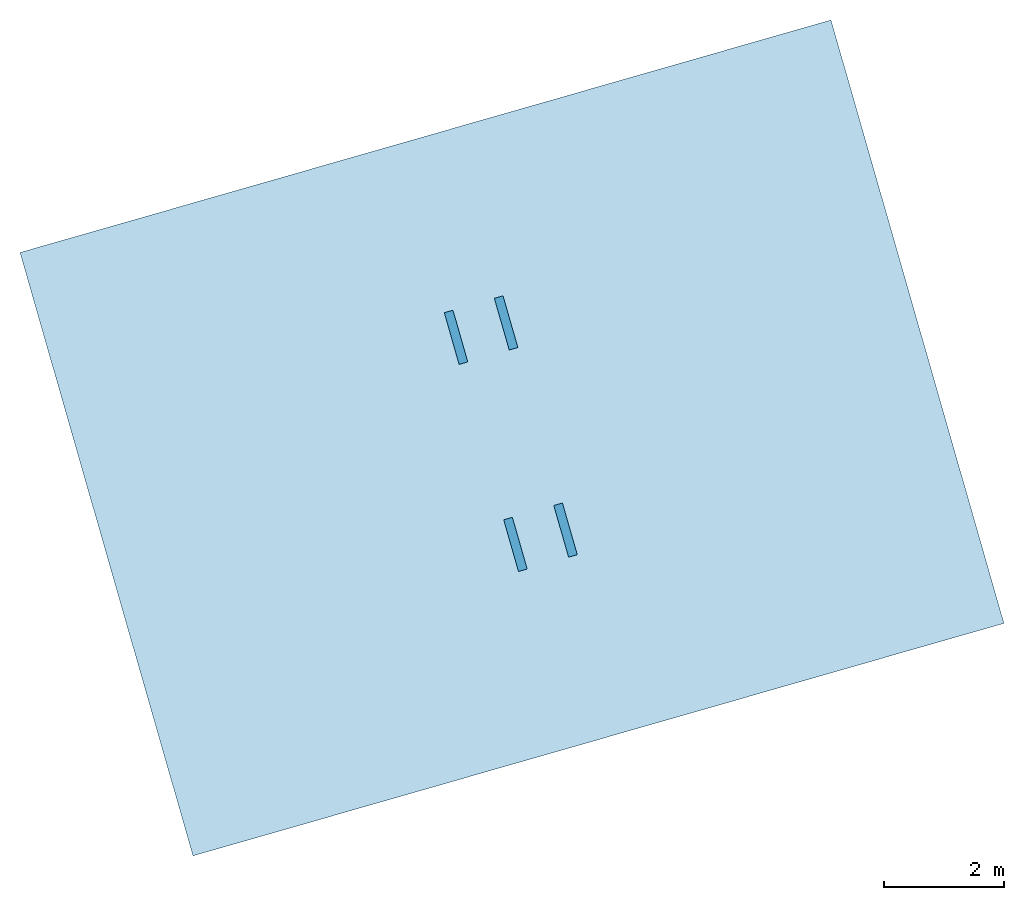
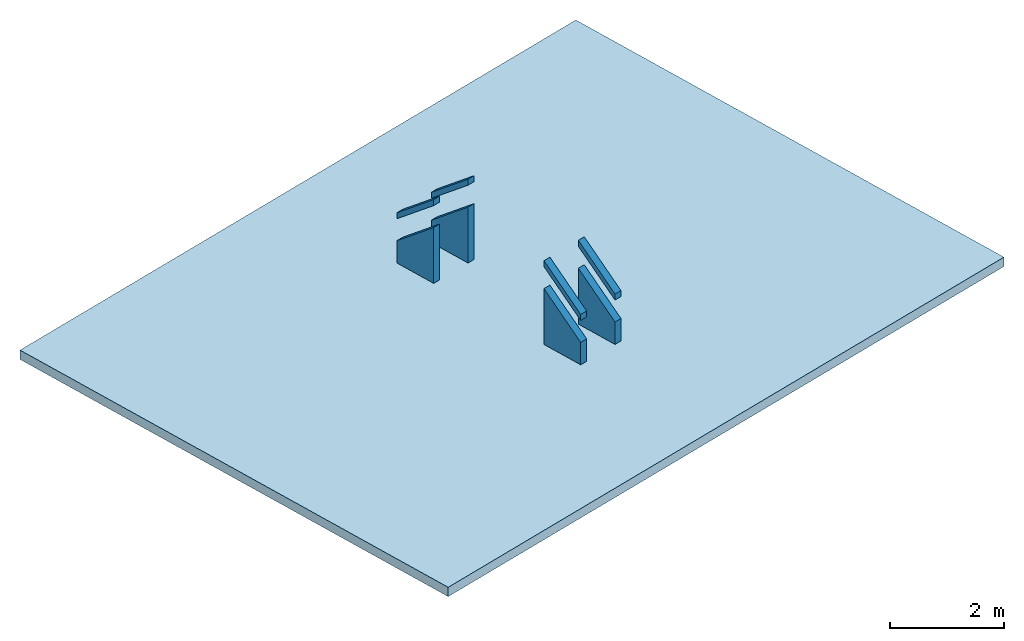
# One storey: 9 slabs.
"""IFC4 building model written with IfcOpenShell, lengths in metres."""

from ifc_helpers import new_model, entity, si_unit, converted_unit, derived_unit, direction, frame, origin_with_axes, place, context, subcontext, project, spatial, polygons, source, transform, mapped, material, type_object, element, save


model = new_model("IFC4")

# Units and contexts
model_context = context("Model", 3, precision=1e-05, world=origin_with_axes(), true_north=direction((0.0, 1.0)))
body_context = subcontext(model_context, "Body", "Model", "MODEL_VIEW")
ifc_project = project(units=[si_unit("LENGTHUNIT", "METRE"), si_unit("AREAUNIT", "SQUARE_METRE"), si_unit("VOLUMEUNIT", "CUBIC_METRE"), converted_unit("PLANEANGLEUNIT", "DEGREE", entity("IfcPlaneAngleMeasure", 0.0174532925199433), si_unit("PLANEANGLEUNIT", "RADIAN"), dimensions=[0, 0, 0, 0, 0, 0, 0]), converted_unit("TIMEUNIT", "Year", entity("IfcTimeMeasure", 31557600.0), si_unit("TIMEUNIT", "SECOND"), dimensions=[0, 0, 1, 0, 0, 0, 0]), si_unit("MASSUNIT", "GRAM", prefix="KILO"), si_unit("THERMODYNAMICTEMPERATUREUNIT", "DEGREE_CELSIUS"), si_unit("LUMINOUSINTENSITYUNIT", "LUMEN"), si_unit("ENERGYUNIT", "JOULE", prefix="MEGA"), derived_unit("THERMALCONDUCTANCEUNIT", [(si_unit("POWERUNIT", "WATT"), 1), (si_unit("LENGTHUNIT", "METRE"), -1), (si_unit("THERMODYNAMICTEMPERATUREUNIT", "KELVIN"), -1)]), derived_unit("SPECIFICHEATCAPACITYUNIT", [(si_unit("ENERGYUNIT", "JOULE"), 1), (si_unit("MASSUNIT", "GRAM", prefix="KILO"), -1), (si_unit("THERMODYNAMICTEMPERATUREUNIT", "KELVIN"), -1)]), derived_unit("MASSDENSITYUNIT", [(si_unit("MASSUNIT", "GRAM", prefix="KILO"), 1), (si_unit("VOLUMEUNIT", "CUBIC_METRE"), -1)])], contexts=[model_context])

# Site, building, storey
site_placement = place(None, frame((0.0, 0.0, 0.0), z_axis=(0.0, 0.0, 1.0), x_axis=(0.9612616959383189, 0.2756373558169991, 0.0)))
site = spatial("IfcSite", under=ifc_project, at=site_placement, CompositionType="ELEMENT")
building_placement = place(site_placement, origin_with_axes())
building = spatial("IfcBuilding", under=site, at=building_placement, CompositionType="ELEMENT")
storey_placement = place(building_placement, frame((0.0, 0.0, -3.0), z_axis=(0.0, 0.0, 1.0), x_axis=(1.0, 0.0, 0.0)))
storey = spatial("IfcBuildingStorey", under=building, at=storey_placement, Name="UG", CompositionType="ELEMENT", Elevation=-3.0)

# Slabs
ifc_material_1 = material()
slab_type_1 = type_object("IfcSlabType", PredefinedType="FLOOR")
shared_shape_1 = source(origin_with_axes(), body_context, "Body", "Tessellation", [
    polygons([(1.086622347656885e-09, -0.8979991308594855, -0.718399304687587), (0.0, 0.0, 0.0), (1.084618617142041e-09, 3.576278828631985e-09, -1.2), (1.086622347656885e-09, -0.8979991308594855, -1.200000000000001), (0.1500000009234412, -0.897999130807264, -0.7183993045908382), (0.1499999998368189, 0.0, 0.0), (0.150000000813294, 3.628500278018976e-09, -1.199999999903251), (0.1500000013153338, -0.897999130807264, -1.199999999903252)], [[[1, 2, 3, 4]], [[2, 1, 5, 6]], [[3, 2, 6, 7]], [[4, 3, 7, 8]], [[1, 4, 8, 5]], [[5, 8, 7, 6]]], closed=True),
])
for number, where, z_axis, x_axis, name in (
    (1, (22.89714550206221, 11.63986881284724, 3.798010511740013), (0.0, 0.0, 1.0), (1.0, 0.0, 0.0), "019"),
    (2, (23.76714550241662, 11.63986881289261, 3.798010511853454), (0.0, 0.0, 1.0), (1.0, 0.0, 0.0), "019"),
):
    element("IfcSlab", number, at=place(storey_placement, frame(where, z_axis=z_axis, x_axis=x_axis)), inside=storey, type_object=slab_type_1, material=ifc_material_1, Name=name, PredefinedType="FLOOR", context=body_context, shape_type="MappedRepresentation", body=[
        mapped(shared_shape_1, transform((0.0, 0.0, 0.0))),
    ])
shared_shape_2 = source(origin_with_axes(), body_context, "Body", "Tessellation", [
    polygons([(-1.086622347656885e-09, -0.8979991308594855, -0.8464617894362444), (-0.1500000006260467, -0.8979991307355002, -0.8464617893752199), (-0.1499999995391951, 0.0001894573524693355, -0.1279109189048459), (-1.039808239511331e-10, 0.00018945722848418, -0.1279109189658703), (-1.086622347656885e-09, -0.8979991308594855, -0.718399304687587), (-0.1500000005703228, -0.8979991307355003, -0.7183993046265625), (-0.1499999994837005, 1.239851554757365e-10, 0.0), (0.0, 0.0, 0.0)], [[[1, 2, 3, 4]], [[5, 6, 2, 1]], [[6, 7, 3, 2]], [[4, 3, 7, 8]], [[5, 1, 4, 8]], [[8, 7, 6, 5]]], closed=True),
])
for number, where, z_axis, x_axis, name in (
    (3, (23.76714550231264, 14.3400582701211, 4.398010511740012), (0.0, 0.0, 1.0), (-1.0, 0.0, 0.0), "023"),
    (4, (22.89714550206221, 14.33986881292418, 4.398010511740012), (0.0, 0.0, 1.0), (-1.0, 0.0, 0.0), "023"),
):
    element("IfcSlab", number, at=place(storey_placement, frame(where, z_axis=z_axis, x_axis=x_axis)), inside=storey, type_object=slab_type_1, material=ifc_material_1, Name=name, PredefinedType="FLOOR", context=body_context, shape_type="MappedRepresentation", body=[
        mapped(shared_shape_2, transform((0.0, 0.0, 0.0))),
    ])
shared_shape_3 = source(origin_with_axes(), body_context, "Body", "Tessellation", [
    polygons([(1.086622347656885e-09, -0.8979991308594855, -0.8464617894362444), (1.039808239511331e-10, 0.00018945722848418, -0.1279109189658703), (0.1499999995391951, 0.0001894573524693355, -0.1279109189048459), (0.1500000006260467, -0.8979991307355002, -0.8464617893752199), (1.086622347656885e-09, -0.8979991308594855, -0.718399304687587), (0.0, 0.0, 0.0), (0.1499999994837005, 1.239851554757365e-10, 0.0), (0.1500000005703228, -0.8979991307355003, -0.7183993046265625)], [[[1, 2, 3, 4]], [[5, 6, 2, 1]], [[2, 6, 7, 3]], [[8, 4, 3, 7]], [[5, 1, 4, 8]], [[6, 5, 8, 7]]], closed=True),
])
for number, where, z_axis, x_axis, name in (
    (5, (22.89714550206221, 11.63986881284724, 4.398010511740012), (0.0, 0.0, 1.0), (1.0, 0.0, 0.0), "023"),
    (6, (23.76714550231264, 11.63967935566413, 4.398010511740012), (0.0, 0.0, 1.0), (1.0, 0.0, 0.0), "023"),
):
    element("IfcSlab", number, at=place(storey_placement, frame(where, z_axis=z_axis, x_axis=x_axis)), inside=storey, type_object=slab_type_1, material=ifc_material_1, Name=name, PredefinedType="FLOOR", context=body_context, shape_type="MappedRepresentation", body=[
        mapped(shared_shape_3, transform((0.0, 0.0, 0.0))),
    ])
shared_shape_4 = source(origin_with_axes(), body_context, "Body", "Tessellation", [
    polygons([(-1.086622347656885e-09, -0.8979991308594855, -0.718399304687587), (-1.086622347656885e-09, -0.8979991308594855, -1.200000000000001), (-1.084618617142041e-09, 3.576278828631985e-09, -1.2), (0.0, 0.0, 0.0), (-0.1500000009234412, -0.897999130807264, -0.7183993045908382), (-0.1500000013153338, -0.897999130807264, -1.199999999903252), (-0.150000000813294, 3.628500278018976e-09, -1.199999999903251), (-0.1499999998368189, 0.0, 0.0)], [[[1, 2, 3, 4]], [[1, 5, 6, 2]], [[2, 6, 7, 3]], [[3, 7, 8, 4]], [[4, 8, 5, 1]], [[5, 8, 7, 6]]], closed=True),
])
for number, where, z_axis, x_axis, name in (
    (7, (22.89714550206221, 14.3398688164689, 3.798010511853455), (0.0, 0.0, 1.0), (-1.0, -6.962845127886468e-10, 0.0), "019"),
    (8, (23.76714550241662, 14.33986881702929, 3.798010511966897), (0.0, 0.0, 1.0), (-1.0, -6.962845127886468e-10, 0.0), "019"),
):
    element("IfcSlab", number, at=place(storey_placement, frame(where, z_axis=z_axis, x_axis=x_axis)), inside=storey, type_object=slab_type_1, material=ifc_material_1, Name=name, PredefinedType="FLOOR", context=body_context, shape_type="MappedRepresentation", body=[
        mapped(shared_shape_4, transform((0.0, 0.0, 0.0))),
    ])
ifc_material_2 = material()
slab_type_2 = type_object("IfcSlabType", Name="200", PredefinedType="FLOOR")
slab_placement = place(storey_placement, frame((16.36285962288927, 7.675401456262026, 2.598010511853345), z_axis=(0.0, 0.0, 1.0), x_axis=(1.0, 0.0, 0.0)))
element("IfcSlab", 9, at=slab_placement, inside=storey, type_object=slab_type_2, material=ifc_material_2, Name="RD-019", PredefinedType="FLOOR", context=body_context, shape_type="Tessellation", body=[
    polygons([(0.0, 0.0, 0.0), (0.0, 0.0, -0.1999999999999998), (14.08857176109777, 0.0, -0.1999999999999998), (14.08857176109777, 0.0, 0.0), (0.0, 10.4812447100612, 0.0), (0.0, 10.4812447100612, -0.1999999999999998), (14.08857176109777, 10.4812447100612, -0.1999999999999998), (14.08857176109777, 10.4812447100612, 0.0)], [[[1, 2, 3, 4]], [[5, 6, 2, 1]], [[3, 2, 6, 7]], [[4, 3, 7, 8]], [[5, 1, 4, 8]], [[8, 7, 6, 5]]], closed=True),
])

save(model, "model.ifc")
